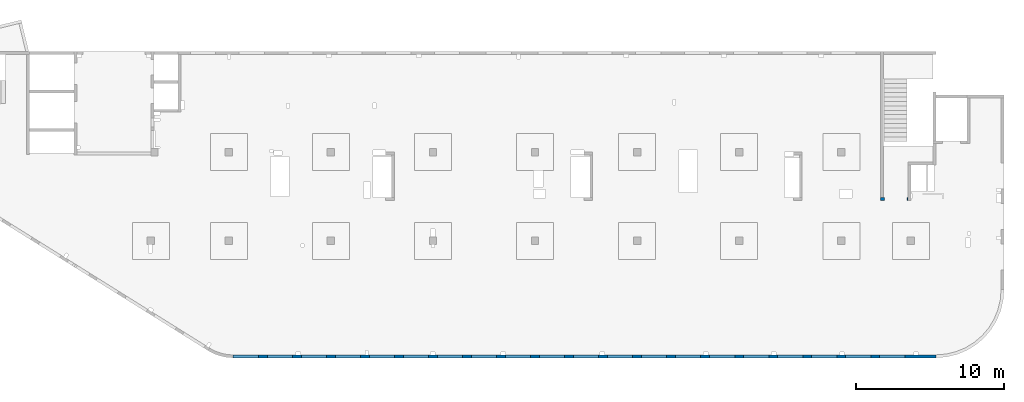
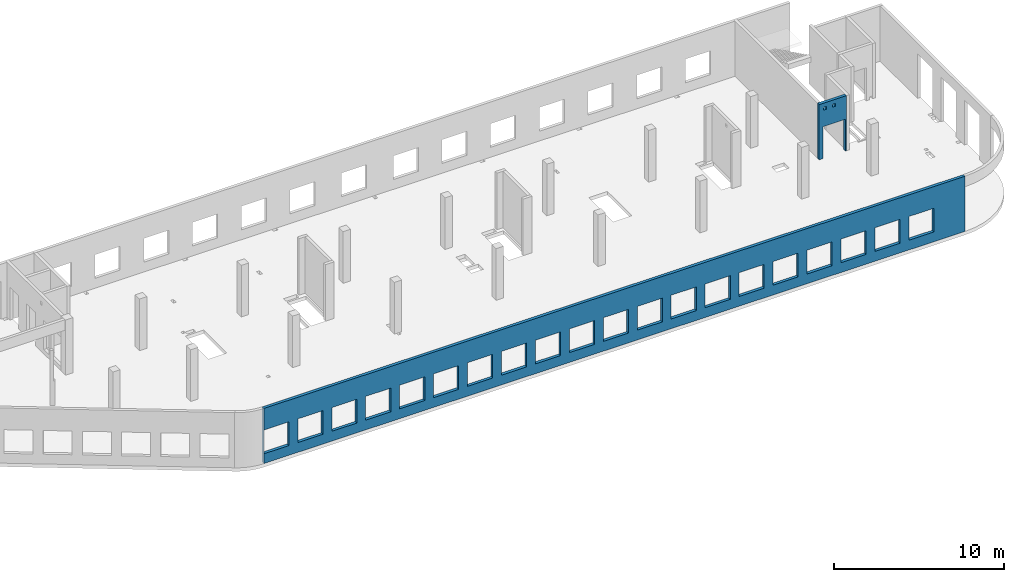
# One storey, part 7 of 8: 2 walls, 23 openings.
"""IFC4 building model written with IfcOpenShell, lengths in millimetres."""

from ifc_helpers import new_model, entity, si_unit, converted_unit, derived_unit, direction, frame, origin, place, context, subcontext, project, spatial, indexed_curve, outline, extrude, polygons, material, type_object, element, save


model = new_model("IFC4")

# Units and contexts
model_context = context("Model", 3, precision=0.01, world=origin(), true_north=direction((6.12303176911189e-17, 1.0)))
plan_context = context("Plan", 3, precision=0.01, world=origin(), true_north=direction((6.12303176911189e-17, 1.0)))
body_context = subcontext(model_context, "Body", "Model", "MODEL_VIEW")
ifc_project = project(units=[si_unit("LENGTHUNIT", "METRE", prefix="MILLI"), si_unit("AREAUNIT", "SQUARE_METRE"), si_unit("VOLUMEUNIT", "CUBIC_METRE"), converted_unit("PLANEANGLEUNIT", "DEGREE", entity("IfcRatioMeasure", 0.0174532925199433), si_unit("PLANEANGLEUNIT", "RADIAN"), dimensions=[0, 0, 0, 0, 0, 0, 0]), si_unit("MASSUNIT", "GRAM", prefix="KILO"), derived_unit("MASSDENSITYUNIT", [(si_unit("MASSUNIT", "GRAM", prefix="KILO"), 1), (si_unit("LENGTHUNIT", "METRE"), -3)]), derived_unit("MOMENTOFINERTIAUNIT", [(si_unit("LENGTHUNIT", "METRE"), 4)]), si_unit("TIMEUNIT", "SECOND"), si_unit("FREQUENCYUNIT", "HERTZ"), si_unit("THERMODYNAMICTEMPERATUREUNIT", "DEGREE_CELSIUS"), derived_unit("THERMALTRANSMITTANCEUNIT", [(si_unit("MASSUNIT", "GRAM", prefix="KILO"), 1), (si_unit("THERMODYNAMICTEMPERATUREUNIT", "KELVIN"), -1), (si_unit("TIMEUNIT", "SECOND"), -3)]), derived_unit("VOLUMETRICFLOWRATEUNIT", [(si_unit("LENGTHUNIT", "METRE"), 3), (si_unit("TIMEUNIT", "SECOND"), -1)]), derived_unit("MASSFLOWRATEUNIT", [(si_unit("MASSUNIT", "GRAM", prefix="KILO"), 1), (si_unit("TIMEUNIT", "SECOND"), -1)]), derived_unit("ROTATIONALFREQUENCYUNIT", [(si_unit("TIMEUNIT", "SECOND"), -1)]), si_unit("ELECTRICCURRENTUNIT", "AMPERE"), si_unit("ELECTRICVOLTAGEUNIT", "VOLT"), si_unit("POWERUNIT", "WATT"), si_unit("FORCEUNIT", "NEWTON", prefix="KILO"), si_unit("ILLUMINANCEUNIT", "LUX"), si_unit("LUMINOUSFLUXUNIT", "LUMEN"), si_unit("LUMINOUSINTENSITYUNIT", "CANDELA"), derived_unit("USERDEFINED", [(si_unit("MASSUNIT", "GRAM", prefix="KILO"), -1), (si_unit("LENGTHUNIT", "METRE"), -2), (si_unit("TIMEUNIT", "SECOND"), 3), (si_unit("LUMINOUSFLUXUNIT", "LUMEN"), 1)]), derived_unit("LINEARVELOCITYUNIT", [(si_unit("LENGTHUNIT", "METRE"), 1), (si_unit("TIMEUNIT", "SECOND"), -1)]), si_unit("PRESSUREUNIT", "PASCAL"), derived_unit("USERDEFINED", [(si_unit("LENGTHUNIT", "METRE"), -2), (si_unit("MASSUNIT", "GRAM", prefix="KILO"), 1), (si_unit("TIMEUNIT", "SECOND"), -2)]), derived_unit("LINEARFORCEUNIT", [(si_unit("MASSUNIT", "GRAM", prefix="KILO"), 1), (si_unit("LENGTHUNIT", "METRE"), 1), (si_unit("TIMEUNIT", "SECOND"), -2), (si_unit("LENGTHUNIT", "METRE"), -1)]), derived_unit("PLANARFORCEUNIT", [(si_unit("MASSUNIT", "GRAM", prefix="KILO"), 1), (si_unit("LENGTHUNIT", "METRE"), 1), (si_unit("TIMEUNIT", "SECOND"), -2), (si_unit("LENGTHUNIT", "METRE"), -2)])], contexts=[model_context, plan_context])

# Site, building, storey
site_placement = place(None, origin())
site = spatial("IfcSite", under=ifc_project, at=site_placement, CompositionType="ELEMENT")
building_placement = place(site_placement, origin())
building = spatial("IfcBuilding", under=site, at=building_placement, CompositionType="ELEMENT")
storey_placement = place(building_placement, frame((0.0, 0.0, 24000.0)))
storey = spatial("IfcBuildingStorey", under=building, at=storey_placement, CompositionType="ELEMENT", Elevation=24000.0)

# Wall, openings
ifc_material = material()
wall_type = type_object("IfcWallType", PredefinedType="STANDARD")
wall_1_placement = place(storey_placement, frame((67080.0002685547, 10524.9992263555, -150.0), z_axis=(0.0, 0.0, 1.0), x_axis=(-1.0, 0.0, 0.0)))
wall_1 = element("IfcWall", 1, at=wall_1_placement, inside=storey, type_object=wall_type, material=ifc_material, PredefinedType="NOTDEFINED", context=body_context, shape_type="Tessellation", body=[
    polygons([(1849.99999999999, -100.000000000001, 3950.0), (1650.0, -100.000000000003, 3950.0), (-9.772240076716e-13, -100.000000000001, 3950.0), (-9.772240076716e-13, -100.000000000001, 0.0), (74.9999999999906, -100.000000000001, 0.0), (74.9999999999906, -100.000000000001, 2279.99999999804), (1575.0, -100.000000000001, 2279.99999999804), (1575.0, -100.000000000003, 0.0), (1650.0, -100.000000000003, 0.0), (1849.99999999999, -100.000000000001, 0.0), (744.999999999994, -100.000000000322, 3650.0), (945.000000000001, -100.000000000324, 3650.0), (945.000000000001, -100.000000000324, 3450.00000000001), (744.999999999994, -100.000000000322, 3450.00000000001), (1349.99999999998, -100.000000000322, 3650.0), (1549.99999999999, -100.000000000322, 3650.0), (1549.99999999999, -100.000000000322, 3450.00000000001), (1349.99999999998, -100.000000000322, 3450.00000000001), (-1.61109744921212e-12, 99.9999999999989, 3950.0), (1849.99999999999, 99.9999999999989, 3950.0), (1849.99999999999, 99.9999999999989, 0.0), (1575.0, 99.9999999999968, 0.0), (1575.0, 99.9999999999968, 2279.99999999804), (74.99999999999, 99.9999999999989, 2279.99999999804), (74.99999999999, 99.9999999999989, 0.0), (-1.61109744921212e-12, 99.9999999999989, 0.0), (945.0, 99.9999999999968, 3650.0), (744.999999999994, 99.9999999999989, 3650.0), (744.999999999994, 99.9999999999989, 3450.00000000001), (945.0, 99.9999999999968, 3450.00000000001), (1549.99999999999, 99.9999999999968, 3650.0), (1349.99999999998, 99.9999999999989, 3650.0), (1349.99999999998, 99.9999999999989, 3450.00000000001), (1549.99999999999, 99.9999999999968, 3450.00000000001)], [[[1, 2, 3, 4, 5, 6, 7, 8, 9, 10], [11, 12, 13, 14], [15, 16, 17, 18]], [[19, 20, 21, 22, 23, 24, 25, 26], [27, 28, 29, 30], [31, 32, 33, 34]], [[4, 26, 25, 5]], [[3, 2, 1, 20, 19]], [[4, 3, 19, 26]], [[1, 10, 21, 20]], [[12, 11, 28, 27]], [[12, 27, 30, 13]], [[13, 30, 29, 14]], [[28, 11, 14, 29]], [[16, 15, 32, 31]], [[16, 31, 34, 17]], [[17, 34, 33, 18]], [[32, 15, 18, 33]], [[6, 24, 23, 7]], [[7, 23, 22, 8]], [[24, 6, 5, 25]], [[21, 10, 9, 8, 22]]], closed=True),
])
opening_1_placement = place(wall_1_placement, frame((67080.0002685547, 10524.9992263555, 150.0), z_axis=(0.0, 0.0, 1.0), x_axis=(-1.0, 0.0, 0.0)))
element("IfcOpeningElement", 2, at=opening_1_placement, cuts=wall_1, PredefinedType="OPENING", context=body_context, shape_type="SweptSolid", body=[
    extrude(outline(indexed_curve([(-750.000000000003, -1139.99999999902), (749.999999999994, -1139.99999999902), (749.999999999994, 1139.99999999902), (-750.000000000003, 1139.99999999902), (-750.000000000003, -1139.99999999902)], self_intersect=False)), frame((66255.0002685547, 10724.9992263575, 990.0), z_axis=(0.0, -1.0, 0.0), x_axis=(-1.0, 0.0, 0.0)), (0.0, 0.0, 1.0), 400.000000001943),
])
opening_2_placement = place(wall_1_placement, frame((67080.0002685547, 10524.9992263555, 150.0), z_axis=(0.0, 0.0, 1.0), x_axis=(-1.0, 0.0, 0.0)))
element("IfcOpeningElement", 3, at=opening_2_placement, cuts=wall_1, PredefinedType="OPENING", context=body_context, shape_type="SweptSolid", body=[
    extrude(outline(indexed_curve([(-99.9999999999946, -99.9999999999946), (100.000000000003, -99.9999999999946), (100.000000000003, 99.9999999999903), (-99.9999999999946, 99.9999999999903), (-99.9999999999946, -99.9999999999946)], self_intersect=False)), frame((65630.0002685547, 10624.9992263565, 3400.0), z_axis=(0.0, -1.0, 0.0), x_axis=(-1.0, 0.0, 0.0)), (0.0, 0.0, 1.0), 200.000000000962),
])
opening_3_placement = place(wall_1_placement, frame((67080.0002685547, 10524.9992263555, 150.0), z_axis=(0.0, 0.0, 1.0), x_axis=(-1.0, 0.0, 0.0)))
element("IfcOpeningElement", 4, at=opening_3_placement, cuts=wall_1, PredefinedType="OPENING", context=body_context, shape_type="SweptSolid", body=[
    extrude(outline(indexed_curve([(-100.000000000003, -99.9999999999946), (99.9999999999946, -99.9999999999946), (99.9999999999946, 99.9999999999903), (-100.000000000003, 99.9999999999903), (-100.000000000003, -99.9999999999946)], self_intersect=False)), frame((66235.0002685547, 10624.9992263565, 3400.0), z_axis=(0.0, -1.0, 0.0), x_axis=(-1.0, 0.0, 0.0)), (0.0, 0.0, 1.0), 200.000000000962),
])

wall_2_placement = place(storey_placement, frame((68970.0002685547, -99.9999557734324, -150.0), z_axis=(0.0, 0.0, 1.0), x_axis=(-1.0, 0.0, 0.0)))
wall_2 = element("IfcWall", 5, at=wall_2_placement, inside=storey, type_object=wall_type, material=ifc_material, PredefinedType="NOTDEFINED", context=body_context, shape_type="Tessellation", body=[
    polygons([(8.66293717728731e-12, -100.0, 0.0), (47510.4829306172, -100.0, 0.0), (47510.4829306172, -100.0, 3950.0), (8.66293717728731e-12, -100.0, 3950.0), (1.42900165493394e-19, -100.0, 3200.0), (45800.0, -100.000000000321, 2400.0), (47500.0, -100.000000000321, 2400.0), (47500.0, -100.000000000321, 700.000000000014), (45800.0, -100.000000000321, 700.000000000014), (43500.0, -100.000000000321, 2400.0), (45200.0, -100.000000000321, 2400.0), (45200.0, -100.000000000321, 700.00000000001), (43500.0, -100.000000000321, 700.00000000001), (41200.0, -100.000000000321, 2400.0), (42900.0, -100.000000000321, 2400.0), (42900.0, -100.000000000321, 700.00000000001), (41200.0, -100.000000000321, 700.00000000001), (38900.0, -100.000000000321, 2400.0), (40600.0, -100.000000000321, 2400.0), (40600.0, -100.000000000321, 700.00000000001), (38900.0, -100.000000000321, 700.00000000001), (36600.0, -100.000000000321, 2400.0), (38300.0, -100.000000000321, 2400.0), (38300.0, -100.000000000321, 700.00000000001), (36600.0, -100.000000000321, 700.00000000001), (34300.0, -100.000000000321, 2400.0), (36000.0, -100.000000000321, 2400.0), (36000.0, -100.000000000321, 700.00000000001), (34300.0, -100.000000000321, 700.00000000001), (32000.0, -100.000000000321, 2400.0), (33700.0, -100.000000000321, 2400.0), (33700.0, -100.000000000321, 700.00000000001), (32000.0, -100.000000000321, 700.00000000001), (29700.0, -100.000000000321, 2400.0), (31400.0, -100.000000000321, 2400.0), (31400.0, -100.000000000321, 700.00000000001), (29700.0, -100.000000000321, 700.00000000001), (27400.0, -100.000000000321, 2400.0), (29100.0, -100.000000000321, 2400.0), (29100.0, -100.000000000321, 700.00000000001), (27400.0, -100.000000000321, 700.00000000001), (25100.0, -100.000000000321, 2400.0), (26800.0, -100.000000000321, 2400.0), (26800.0, -100.000000000321, 700.00000000001), (25100.0, -100.000000000321, 700.00000000001), (22800.0, -100.000000000321, 2400.0), (24500.0, -100.000000000321, 2400.0), (24500.0, -100.000000000321, 700.00000000001), (22800.0, -100.000000000321, 700.00000000001), (20500.0, -100.000000000321, 2400.0), (22200.0, -100.000000000321, 2400.0), (22200.0, -100.000000000321, 700.00000000001), (20500.0, -100.000000000321, 700.00000000001), (18200.0, -100.000000000321, 2400.0), (19900.0, -100.000000000321, 2400.0), (19900.0, -100.000000000321, 700.00000000001), (18200.0, -100.000000000321, 700.00000000001), (15900.0, -100.000000000321, 2400.0), (17600.0, -100.000000000321, 2400.0), (17600.0, -100.000000000321, 700.00000000001), (15900.0, -100.000000000321, 700.00000000001), (13600.0, -100.000000000321, 2400.0), (15300.0, -100.000000000321, 2400.0), (15300.0, -100.000000000321, 700.00000000001), (13600.0, -100.000000000321, 700.00000000001), (11300.0, -100.000000000321, 2400.0), (13000.0, -100.000000000321, 2400.0), (13000.0, -100.000000000321, 700.00000000001), (11300.0, -100.000000000321, 700.00000000001), (8999.99999999998, -100.000000000321, 2400.0), (10700.0, -100.000000000321, 2400.0), (10700.0, -100.000000000321, 700.00000000001), (8999.99999999998, -100.000000000321, 700.00000000001), (6699.99999999998, -100.000000000321, 2400.0), (8399.99999999997, -100.000000000321, 2400.0), (8399.99999999997, -100.000000000321, 700.00000000001), (6699.99999999998, -100.000000000321, 700.00000000001), (4399.99999999998, -100.000000000321, 2400.0), (6099.99999999997, -100.000000000321, 2400.0), (6099.99999999997, -100.000000000321, 700.00000000001), (4399.99999999998, -100.000000000321, 700.00000000001), (2099.99999999998, -100.000000000321, 2400.0), (3799.99999999998, -100.000000000321, 2400.0), (3799.99999999998, -100.000000000321, 700.00000000001), (2099.99999999998, -100.000000000321, 700.00000000001), (47510.4829306172, 100.0, 0.0), (8.01671852045731e-12, 100.0, 0.0), (-6.46218513929826e-13, 100.0, 3200.0), (8.01671852045731e-12, 100.0, 3950.0), (47510.4829306172, 100.0, 3950.0), (47500.0, 100.0, 2400.0), (45800.0, 100.0, 2400.0), (45800.0, 100.0, 700.00000000001), (47500.0, 100.0, 700.00000000001), (45200.0, 100.0, 2400.0), (43500.0, 100.0, 2400.0), (43500.0, 100.0, 700.00000000001), (45200.0, 100.0, 700.00000000001), (42900.0, 100.0, 2400.0), (41200.0, 100.0, 2400.0), (41200.0, 100.0, 700.00000000001), (42900.0, 100.0, 700.00000000001), (40600.0, 100.0, 2400.0), (38900.0, 100.0, 2400.0), (38900.0, 100.0, 700.00000000001), (40600.0, 100.0, 700.00000000001), (38300.0, 100.0, 2400.0), (36600.0, 100.0, 2400.0), (36600.0, 100.0, 700.00000000001), (38300.0, 100.0, 700.00000000001), (36000.0, 100.0, 2400.0), (34300.0, 100.0, 2400.0), (34300.0, 100.0, 700.00000000001), (36000.0, 100.0, 700.00000000001), (33700.0, 100.0, 2400.0), (32000.0, 100.0, 2400.0), (32000.0, 100.0, 700.00000000001), (33700.0, 100.0, 700.00000000001), (31400.0, 100.0, 2400.0), (29700.0, 100.0, 2400.0), (29700.0, 100.0, 700.00000000001), (31400.0, 100.0, 700.00000000001), (29100.0, 100.0, 2400.0), (27400.0, 100.0, 2400.0), (27400.0, 100.0, 700.00000000001), (29100.0, 100.0, 700.00000000001), (26800.0, 100.0, 2400.0), (25100.0, 100.0, 2400.0), (25100.0, 100.0, 700.00000000001), (26800.0, 100.0, 700.00000000001), (24500.0, 100.0, 2400.0), (22800.0, 100.0, 2400.0), (22800.0, 100.0, 700.00000000001), (24500.0, 100.0, 700.00000000001), (22200.0, 100.0, 2400.0), (20500.0, 100.0, 2400.0), (20500.0, 100.0, 700.00000000001), (22200.0, 100.0, 700.00000000001), (19900.0, 100.0, 2400.0), (18200.0, 100.0, 2400.0), (18200.0, 100.0, 700.00000000001), (19900.0, 100.0, 700.00000000001), (17600.0, 100.0, 2400.0), (15900.0, 100.0, 2400.0), (15900.0, 100.0, 700.00000000001), (17600.0, 100.0, 700.00000000001), (15300.0, 100.0, 2400.0), (13600.0, 100.0, 2400.0), (13600.0, 100.0, 700.00000000001), (15300.0, 100.0, 700.00000000001), (13000.0, 100.0, 2400.0), (11300.0, 100.0, 2400.0), (11300.0, 100.0, 700.00000000001), (13000.0, 100.0, 700.00000000001), (10700.0, 100.0, 2400.0), (8999.99999999998, 100.0, 2400.0), (8999.99999999998, 100.0, 700.00000000001), (10700.0, 100.0, 700.00000000001), (8399.99999999997, 100.0, 2400.0), (6699.99999999997, 100.0, 2400.0), (6699.99999999997, 100.0, 700.00000000001), (8399.99999999997, 100.0, 700.00000000001), (6099.99999999997, 100.0, 2400.0), (4399.99999999998, 100.0, 2400.0), (4399.99999999998, 100.0, 700.00000000001), (6099.99999999997, 100.0, 700.00000000001), (3799.99999999998, 100.0, 2400.0), (2099.99999999998, 100.0, 2400.0), (2099.99999999998, 100.0, 700.00000000001), (3799.99999999998, 100.0, 700.00000000001)], [[[1, 2, 3, 4, 5], [6, 7, 8, 9], [10, 11, 12, 13], [14, 15, 16, 17], [18, 19, 20, 21], [22, 23, 24, 25], [26, 27, 28, 29], [30, 31, 32, 33], [34, 35, 36, 37], [38, 39, 40, 41], [42, 43, 44, 45], [46, 47, 48, 49], [50, 51, 52, 53], [54, 55, 56, 57], [58, 59, 60, 61], [62, 63, 64, 65], [66, 67, 68, 69], [70, 71, 72, 73], [74, 75, 76, 77], [78, 79, 80, 81], [82, 83, 84, 85]], [[86, 87, 88, 89, 90], [91, 92, 93, 94], [95, 96, 97, 98], [99, 100, 101, 102], [103, 104, 105, 106], [107, 108, 109, 110], [111, 112, 113, 114], [115, 116, 117, 118], [119, 120, 121, 122], [123, 124, 125, 126], [127, 128, 129, 130], [131, 132, 133, 134], [135, 136, 137, 138], [139, 140, 141, 142], [143, 144, 145, 146], [147, 148, 149, 150], [151, 152, 153, 154], [155, 156, 157, 158], [159, 160, 161, 162], [163, 164, 165, 166], [167, 168, 169, 170]], [[2, 1, 87, 86]], [[3, 2, 86, 90]], [[4, 3, 90, 89]], [[1, 5, 4, 89, 88, 87]], [[91, 7, 6, 92]], [[7, 91, 94, 8]], [[8, 94, 93, 9]], [[92, 6, 9, 93]], [[11, 10, 96, 95]], [[11, 95, 98, 12]], [[12, 98, 97, 13]], [[96, 10, 13, 97]], [[15, 14, 100, 99]], [[15, 99, 102, 16]], [[16, 102, 101, 17]], [[100, 14, 17, 101]], [[19, 18, 104, 103]], [[19, 103, 106, 20]], [[20, 106, 105, 21]], [[104, 18, 21, 105]], [[23, 22, 108, 107]], [[23, 107, 110, 24]], [[24, 110, 109, 25]], [[108, 22, 25, 109]], [[27, 26, 112, 111]], [[27, 111, 114, 28]], [[28, 114, 113, 29]], [[112, 26, 29, 113]], [[31, 30, 116, 115]], [[31, 115, 118, 32]], [[32, 118, 117, 33]], [[116, 30, 33, 117]], [[35, 34, 120, 119]], [[35, 119, 122, 36]], [[36, 122, 121, 37]], [[120, 34, 37, 121]], [[39, 38, 124, 123]], [[39, 123, 126, 40]], [[40, 126, 125, 41]], [[124, 38, 41, 125]], [[43, 42, 128, 127]], [[43, 127, 130, 44]], [[44, 130, 129, 45]], [[128, 42, 45, 129]], [[47, 46, 132, 131]], [[47, 131, 134, 48]], [[48, 134, 133, 49]], [[132, 46, 49, 133]], [[51, 50, 136, 135]], [[51, 135, 138, 52]], [[52, 138, 137, 53]], [[136, 50, 53, 137]], [[55, 54, 140, 139]], [[55, 139, 142, 56]], [[56, 142, 141, 57]], [[140, 54, 57, 141]], [[59, 58, 144, 143]], [[59, 143, 146, 60]], [[60, 146, 145, 61]], [[144, 58, 61, 145]], [[63, 62, 148, 147]], [[63, 147, 150, 64]], [[64, 150, 149, 65]], [[148, 62, 65, 149]], [[67, 66, 152, 151]], [[67, 151, 154, 68]], [[68, 154, 153, 69]], [[152, 66, 69, 153]], [[71, 70, 156, 155]], [[71, 155, 158, 72]], [[72, 158, 157, 73]], [[156, 70, 73, 157]], [[75, 74, 160, 159]], [[75, 159, 162, 76]], [[76, 162, 161, 77]], [[160, 74, 77, 161]], [[79, 78, 164, 163]], [[79, 163, 166, 80]], [[80, 166, 165, 81]], [[164, 78, 81, 165]], [[83, 82, 168, 167]], [[83, 167, 170, 84]], [[84, 170, 169, 85]], [[168, 82, 85, 169]]], closed=True),
])
opening_4_placement = place(wall_2_placement, frame((68970.0002685547, -99.9999557734324, 150.0), z_axis=(0.0, 0.0, 1.0), x_axis=(-1.0, 0.0, 0.0)))
element("IfcOpeningElement", 6, at=opening_4_placement, cuts=wall_2, PredefinedType="OPENING", context=body_context, shape_type="SweptSolid", body=[
    extrude(outline(indexed_curve([(-850.000000000002, -849.999999999993), (849.999999999997, -849.999999999993), (849.999999999997, 849.999999999993), (-850.000000000002, 849.999999999993), (-850.000000000002, -849.999999999993)], self_intersect=False)), frame((22320.0002685547, 4.42276800359536e-05, 1400.0), z_axis=(0.0, -1.0, 0.0), x_axis=(-1.0, 0.0, 0.0)), (0.0, 0.0, 1.0), 200.000000000962),
])
opening_5_placement = place(wall_2_placement, frame((68970.0002685547, -99.9999557734324, 150.0), z_axis=(0.0, 0.0, 1.0), x_axis=(-1.0, 0.0, 0.0)))
element("IfcOpeningElement", 7, at=opening_5_placement, cuts=wall_2, PredefinedType="OPENING", context=body_context, shape_type="SweptSolid", body=[
    extrude(outline(indexed_curve([(-849.999999999997, -849.999999999993), (850.000000000006, -849.999999999993), (850.000000000006, 849.999999999993), (-849.999999999997, 849.999999999993), (-849.999999999997, -849.999999999993)], self_intersect=False)), frame((66020.0002685547, 4.4227538823312e-05, 1400.0), z_axis=(0.0, -1.0, 0.0), x_axis=(-1.0, 0.0, 0.0)), (0.0, 0.0, 1.0), 200.000000000962),
])
opening_6_placement = place(wall_2_placement, frame((68970.0002685547, -99.9999557734324, 150.0), z_axis=(0.0, 0.0, 1.0), x_axis=(-1.0, 0.0, 0.0)))
element("IfcOpeningElement", 8, at=opening_6_placement, cuts=wall_2, PredefinedType="OPENING", context=body_context, shape_type="SweptSolid", body=[
    extrude(outline(indexed_curve([(-849.999999999997, -849.999999999993), (850.000000000006, -849.999999999993), (850.000000000006, 849.999999999993), (-849.999999999997, 849.999999999993), (-849.999999999997, -849.999999999993)], self_intersect=False)), frame((63720.0002685547, 4.42275462680235e-05, 1400.0), z_axis=(0.0, -1.0, 0.0), x_axis=(-1.0, 0.0, 0.0)), (0.0, 0.0, 1.0), 200.000000000962),
])
opening_7_placement = place(wall_2_placement, frame((68970.0002685547, -99.9999557734324, 150.0), z_axis=(0.0, 0.0, 1.0), x_axis=(-1.0, 0.0, 0.0)))
element("IfcOpeningElement", 9, at=opening_7_placement, cuts=wall_2, PredefinedType="OPENING", context=body_context, shape_type="SweptSolid", body=[
    extrude(outline(indexed_curve([(-849.999999999997, -849.999999999993), (850.000000000006, -849.999999999993), (850.000000000006, 849.999999999993), (-849.999999999997, 849.999999999993), (-849.999999999997, -849.999999999993)], self_intersect=False)), frame((61420.0002685547, 4.42275536958152e-05, 1400.0), z_axis=(0.0, -1.0, 0.0), x_axis=(-1.0, 0.0, 0.0)), (0.0, 0.0, 1.0), 200.000000000962),
])
opening_8_placement = place(wall_2_placement, frame((68970.0002685547, -99.9999557734324, 150.0), z_axis=(0.0, 0.0, 1.0), x_axis=(-1.0, 0.0, 0.0)))
element("IfcOpeningElement", 10, at=opening_8_placement, cuts=wall_2, PredefinedType="OPENING", context=body_context, shape_type="SweptSolid", body=[
    extrude(outline(indexed_curve([(-849.999999999997, -849.999999999993), (850.000000000006, -849.999999999993), (850.000000000006, 849.999999999993), (-849.999999999997, 849.999999999993), (-849.999999999997, -849.999999999993)], self_intersect=False)), frame((59120.0002685547, 4.4227561123607e-05, 1400.0), z_axis=(0.0, -1.0, 0.0), x_axis=(-1.0, 0.0, 0.0)), (0.0, 0.0, 1.0), 200.000000000962),
])
opening_9_placement = place(wall_2_placement, frame((68970.0002685547, -99.9999557734324, 150.0), z_axis=(0.0, 0.0, 1.0), x_axis=(-1.0, 0.0, 0.0)))
element("IfcOpeningElement", 11, at=opening_9_placement, cuts=wall_2, PredefinedType="OPENING", context=body_context, shape_type="SweptSolid", body=[
    extrude(outline(indexed_curve([(-849.999999999997, -849.999999999993), (850.000000000006, -849.999999999993), (850.000000000006, 849.999999999993), (-849.999999999997, 849.999999999993), (-849.999999999997, -849.999999999993)], self_intersect=False)), frame((56820.0002685547, 4.42275685513987e-05, 1400.0), z_axis=(0.0, -1.0, 0.0), x_axis=(-1.0, 0.0, 0.0)), (0.0, 0.0, 1.0), 200.000000000962),
])
opening_10_placement = place(wall_2_placement, frame((68970.0002685547, -99.9999557734324, 150.0), z_axis=(0.0, 0.0, 1.0), x_axis=(-1.0, 0.0, 0.0)))
element("IfcOpeningElement", 12, at=opening_10_placement, cuts=wall_2, PredefinedType="OPENING", context=body_context, shape_type="SweptSolid", body=[
    extrude(outline(indexed_curve([(-849.999999999997, -849.999999999993), (850.000000000006, -849.999999999993), (850.000000000006, 849.999999999993), (-849.999999999997, 849.999999999993), (-849.999999999997, -849.999999999993)], self_intersect=False)), frame((54520.0002685547, 4.42275759791904e-05, 1400.0), z_axis=(0.0, -1.0, 0.0), x_axis=(-1.0, 0.0, 0.0)), (0.0, 0.0, 1.0), 200.000000000962),
])
opening_11_placement = place(wall_2_placement, frame((68970.0002685547, -99.9999557734324, 150.0), z_axis=(0.0, 0.0, 1.0), x_axis=(-1.0, 0.0, 0.0)))
element("IfcOpeningElement", 13, at=opening_11_placement, cuts=wall_2, PredefinedType="OPENING", context=body_context, shape_type="SweptSolid", body=[
    extrude(outline(indexed_curve([(-849.999999999997, -849.999999999993), (850.000000000006, -849.999999999993), (850.000000000006, 849.999999999993), (-849.999999999997, 849.999999999993), (-849.999999999997, -849.999999999993)], self_intersect=False)), frame((52220.0002685547, 4.42275834239019e-05, 1400.0), z_axis=(0.0, -1.0, 0.0), x_axis=(-1.0, 0.0, 0.0)), (0.0, 0.0, 1.0), 200.000000000962),
])
opening_12_placement = place(wall_2_placement, frame((68970.0002685547, -99.9999557734324, 150.0), z_axis=(0.0, 0.0, 1.0), x_axis=(-1.0, 0.0, 0.0)))
element("IfcOpeningElement", 14, at=opening_12_placement, cuts=wall_2, PredefinedType="OPENING", context=body_context, shape_type="SweptSolid", body=[
    extrude(outline(indexed_curve([(-849.999999999997, -849.999999999993), (850.000000000006, -849.999999999993), (850.000000000006, 849.999999999993), (-849.999999999997, 849.999999999993), (-849.999999999997, -849.999999999993)], self_intersect=False)), frame((49920.0002685547, 4.42275908516936e-05, 1400.0), z_axis=(0.0, -1.0, 0.0), x_axis=(-1.0, 0.0, 0.0)), (0.0, 0.0, 1.0), 200.000000000962),
])
opening_13_placement = place(wall_2_placement, frame((68970.0002685547, -99.9999557734324, 150.0), z_axis=(0.0, 0.0, 1.0), x_axis=(-1.0, 0.0, 0.0)))
element("IfcOpeningElement", 15, at=opening_13_placement, cuts=wall_2, PredefinedType="OPENING", context=body_context, shape_type="SweptSolid", body=[
    extrude(outline(indexed_curve([(-849.999999999997, -849.999999999993), (850.000000000006, -849.999999999993), (850.000000000006, 849.999999999993), (-849.999999999997, 849.999999999993), (-849.999999999997, -849.999999999993)], self_intersect=False)), frame((47620.0002685547, 4.42275982794853e-05, 1400.0), z_axis=(0.0, -1.0, 0.0), x_axis=(-1.0, 0.0, 0.0)), (0.0, 0.0, 1.0), 200.000000000962),
])
opening_14_placement = place(wall_2_placement, frame((68970.0002685547, -99.9999557734324, 150.0), z_axis=(0.0, 0.0, 1.0), x_axis=(-1.0, 0.0, 0.0)))
element("IfcOpeningElement", 16, at=opening_14_placement, cuts=wall_2, PredefinedType="OPENING", context=body_context, shape_type="SweptSolid", body=[
    extrude(outline(indexed_curve([(-849.999999999997, -849.999999999993), (850.000000000006, -849.999999999993), (850.000000000006, 849.999999999993), (-849.999999999997, 849.999999999993), (-849.999999999997, -849.999999999993)], self_intersect=False)), frame((45320.0002685547, 4.4227605707277e-05, 1400.0), z_axis=(0.0, -1.0, 0.0), x_axis=(-1.0, 0.0, 0.0)), (0.0, 0.0, 1.0), 200.000000000962),
])
opening_15_placement = place(wall_2_placement, frame((68970.0002685547, -99.9999557734324, 150.0), z_axis=(0.0, 0.0, 1.0), x_axis=(-1.0, 0.0, 0.0)))
element("IfcOpeningElement", 17, at=opening_15_placement, cuts=wall_2, PredefinedType="OPENING", context=body_context, shape_type="SweptSolid", body=[
    extrude(outline(indexed_curve([(-849.999999999997, -849.999999999993), (850.000000000006, -849.999999999993), (850.000000000006, 849.999999999993), (-849.999999999997, 849.999999999993), (-849.999999999997, -849.999999999993)], self_intersect=False)), frame((43020.0002685547, 4.42276131519886e-05, 1400.0), z_axis=(0.0, -1.0, 0.0), x_axis=(-1.0, 0.0, 0.0)), (0.0, 0.0, 1.0), 200.000000000962),
])
opening_16_placement = place(wall_2_placement, frame((68970.0002685547, -99.9999557734324, 150.0), z_axis=(0.0, 0.0, 1.0), x_axis=(-1.0, 0.0, 0.0)))
element("IfcOpeningElement", 18, at=opening_16_placement, cuts=wall_2, PredefinedType="OPENING", context=body_context, shape_type="SweptSolid", body=[
    extrude(outline(indexed_curve([(-849.999999999997, -849.999999999993), (850.000000000006, -849.999999999993), (850.000000000006, 849.999999999993), (-849.999999999997, 849.999999999993), (-849.999999999997, -849.999999999993)], self_intersect=False)), frame((40720.0002685547, 4.42276205797803e-05, 1400.0), z_axis=(0.0, -1.0, 0.0), x_axis=(-1.0, 0.0, 0.0)), (0.0, 0.0, 1.0), 200.000000000962),
])
opening_17_placement = place(wall_2_placement, frame((68970.0002685547, -99.9999557734324, 150.0), z_axis=(0.0, 0.0, 1.0), x_axis=(-1.0, 0.0, 0.0)))
element("IfcOpeningElement", 19, at=opening_17_placement, cuts=wall_2, PredefinedType="OPENING", context=body_context, shape_type="SweptSolid", body=[
    extrude(outline(indexed_curve([(-849.999999999997, -849.999999999993), (850.000000000002, -849.999999999993), (850.000000000002, 849.999999999993), (-849.999999999997, 849.999999999993), (-849.999999999997, -849.999999999993)], self_intersect=False)), frame((38420.0002685547, 4.4227628007572e-05, 1400.0), z_axis=(0.0, -1.0, 0.0), x_axis=(-1.0, 0.0, 0.0)), (0.0, 0.0, 1.0), 200.000000000962),
])
opening_18_placement = place(wall_2_placement, frame((68970.0002685547, -99.9999557734324, 150.0), z_axis=(0.0, 0.0, 1.0), x_axis=(-1.0, 0.0, 0.0)))
element("IfcOpeningElement", 20, at=opening_18_placement, cuts=wall_2, PredefinedType="OPENING", context=body_context, shape_type="SweptSolid", body=[
    extrude(outline(indexed_curve([(-849.999999999997, -849.999999999993), (850.000000000002, -849.999999999993), (850.000000000002, 849.999999999993), (-849.999999999997, 849.999999999993), (-849.999999999997, -849.999999999993)], self_intersect=False)), frame((36120.0002685547, 4.42276354353637e-05, 1400.0), z_axis=(0.0, -1.0, 0.0), x_axis=(-1.0, 0.0, 0.0)), (0.0, 0.0, 1.0), 200.000000000962),
])
opening_19_placement = place(wall_2_placement, frame((68970.0002685547, -99.9999557734324, 150.0), z_axis=(0.0, 0.0, 1.0), x_axis=(-1.0, 0.0, 0.0)))
element("IfcOpeningElement", 21, at=opening_19_placement, cuts=wall_2, PredefinedType="OPENING", context=body_context, shape_type="SweptSolid", body=[
    extrude(outline(indexed_curve([(-849.999999999997, -849.999999999993), (850.000000000002, -849.999999999993), (850.000000000002, 849.999999999993), (-849.999999999997, 849.999999999993), (-849.999999999997, -849.999999999993)], self_intersect=False)), frame((33820.0002685547, 4.42276428631554e-05, 1400.0), z_axis=(0.0, -1.0, 0.0), x_axis=(-1.0, 0.0, 0.0)), (0.0, 0.0, 1.0), 200.000000000962),
])
opening_20_placement = place(wall_2_placement, frame((68970.0002685547, -99.9999557734324, 150.0), z_axis=(0.0, 0.0, 1.0), x_axis=(-1.0, 0.0, 0.0)))
element("IfcOpeningElement", 22, at=opening_20_placement, cuts=wall_2, PredefinedType="OPENING", context=body_context, shape_type="SweptSolid", body=[
    extrude(outline(indexed_curve([(-849.999999999997, -849.999999999993), (850.000000000002, -849.999999999993), (850.000000000002, 849.999999999993), (-849.999999999997, 849.999999999993), (-849.999999999997, -849.999999999993)], self_intersect=False)), frame((31520.0002685547, 4.42276503078669e-05, 1400.0), z_axis=(0.0, -1.0, 0.0), x_axis=(-1.0, 0.0, 0.0)), (0.0, 0.0, 1.0), 200.000000000962),
])
opening_21_placement = place(wall_2_placement, frame((68970.0002685547, -99.9999557734324, 150.0), z_axis=(0.0, 0.0, 1.0), x_axis=(-1.0, 0.0, 0.0)))
element("IfcOpeningElement", 23, at=opening_21_placement, cuts=wall_2, PredefinedType="OPENING", context=body_context, shape_type="SweptSolid", body=[
    extrude(outline(indexed_curve([(-850.000000000002, -849.999999999993), (849.999999999997, -849.999999999993), (849.999999999997, 849.999999999993), (-850.000000000002, 849.999999999993), (-850.000000000002, -849.999999999993)], self_intersect=False)), frame((29220.0002685547, 4.42276577356586e-05, 1400.0), z_axis=(0.0, -1.0, 0.0), x_axis=(-1.0, 0.0, 0.0)), (0.0, 0.0, 1.0), 200.000000000962),
])
opening_22_placement = place(wall_2_placement, frame((68970.0002685547, -99.9999557734324, 150.0), z_axis=(0.0, 0.0, 1.0), x_axis=(-1.0, 0.0, 0.0)))
element("IfcOpeningElement", 24, at=opening_22_placement, cuts=wall_2, PredefinedType="OPENING", context=body_context, shape_type="SweptSolid", body=[
    extrude(outline(indexed_curve([(-850.000000000002, -849.999999999993), (849.999999999997, -849.999999999993), (849.999999999997, 849.999999999993), (-850.000000000002, 849.999999999993), (-850.000000000002, -849.999999999993)], self_intersect=False)), frame((26920.0002685547, 4.42276651634504e-05, 1400.0), z_axis=(0.0, -1.0, 0.0), x_axis=(-1.0, 0.0, 0.0)), (0.0, 0.0, 1.0), 200.000000000962),
])
opening_23_placement = place(wall_2_placement, frame((68970.0002685547, -99.9999557734324, 150.0), z_axis=(0.0, 0.0, 1.0), x_axis=(-1.0, 0.0, 0.0)))
element("IfcOpeningElement", 25, at=opening_23_placement, cuts=wall_2, PredefinedType="OPENING", context=body_context, shape_type="SweptSolid", body=[
    extrude(outline(indexed_curve([(-850.000000000002, -849.999999999993), (849.999999999997, -849.999999999993), (849.999999999997, 849.999999999993), (-850.000000000002, 849.999999999993), (-850.000000000002, -849.999999999993)], self_intersect=False)), frame((24620.0002685547, 4.42276725912421e-05, 1400.0), z_axis=(0.0, -1.0, 0.0), x_axis=(-1.0, 0.0, 0.0)), (0.0, 0.0, 1.0), 200.000000000962),
])

save(model, "model.ifc")
